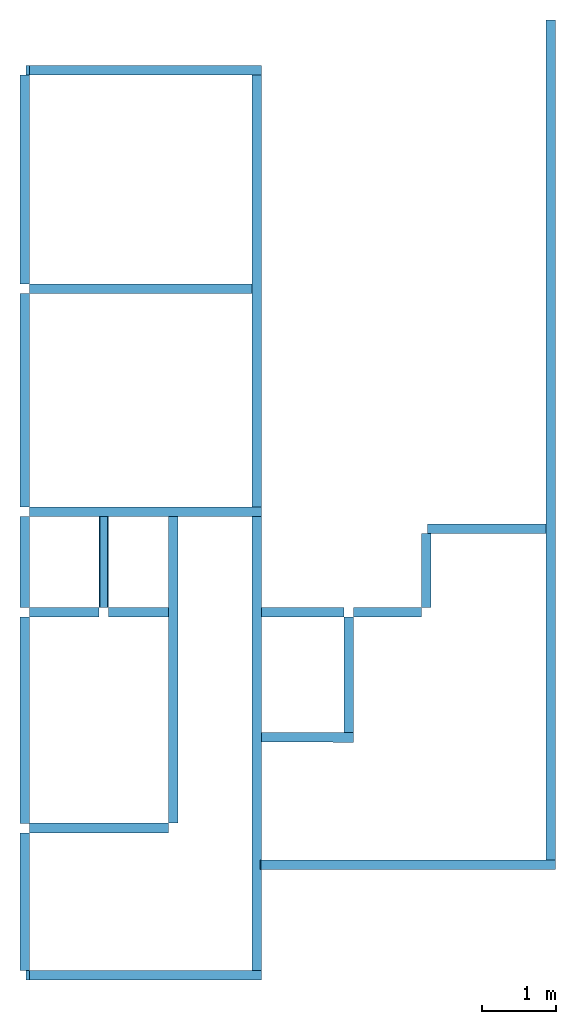
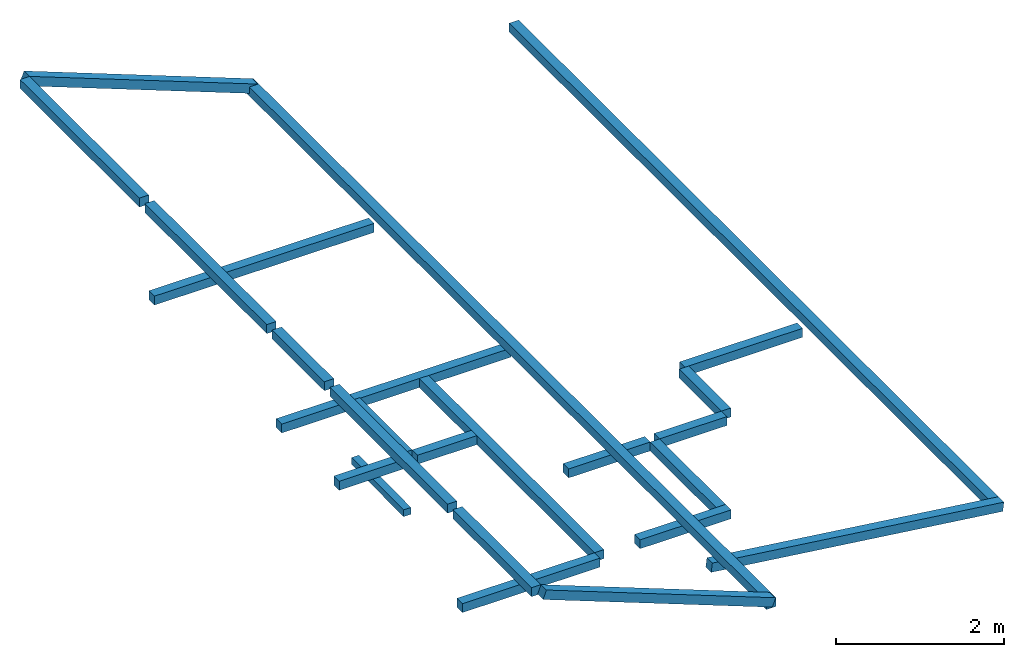
# One storey: 24 beams.
"""IFC4 building model written with IfcOpenShell, lengths in millimetres."""

import ifcopenshell
import ifcopenshell.guid

model = None  # the IFC model being written
_history = None  # IfcOwnerHistory: only IFC2X3 demands one
_inside = {}  # id of a spatial element -> (the spatial element, [elements in it])
_under = {}  # id of a project, library or spatial element -> (it, [spatial elements below it])
_declared = {}  # id of a project -> (the project, [libraries it declares])
_typed = {}  # id of a type object -> (the type object, [elements of that type])
_made_of = {}  # id of a material, layer set ... -> (it, [elements and type objects made of it])


def new_model(schema):
    """Start an empty IFC model of exactly this schema.

    Asked for "IFC4X3", IfcOpenShell would pick the latest addendum, in which some entities
    have other attributes; the version numbers below select the first issue.
    IFC2X3 requires an IfcOwnerHistory on every rooted entity: one is made here for all.
    """
    global model, _history
    if schema == "IFC4X3":
        model = ifcopenshell.file(schema_version=(4, 3, 0, 0))
    else:
        model = ifcopenshell.file(schema=schema)
    _inside.clear()
    _under.clear()
    _declared.clear()
    _typed.clear()
    _made_of.clear()
    _history = None
    if model.schema == "IFC2X3":
        org = make("IfcOrganization", Name="unknown")
        user = make(
            "IfcPersonAndOrganization",
            ThePerson=make("IfcPerson", FamilyName="unknown"),
            TheOrganization=org,
        )
        app = make(
            "IfcApplication",
            ApplicationDeveloper=org,
            Version="unknown",
            ApplicationFullName="unknown",
            ApplicationIdentifier="unknown",
        )
        _history = make(
            "IfcOwnerHistory",
            OwningUser=user,
            OwningApplication=app,
            ChangeAction="ADDED",
            CreationDate=0,
        )
    return model


def make(cls, **values):
    """One entity of the class cls with the attributes given. An attribute that is None is left unset."""
    return model.create_entity(
        cls, **{name: value for name, value in values.items() if value is not None}
    )


def entity(cls, *values):
    """Any entity or typed value of the class cls, its attributes in the order of the schema. None: left unset."""
    e = model.create_entity(cls)
    for i, value in enumerate(values):
        if value is not None:
            e[i] = value
    return e


def rooted(cls, **values):
    """An entity with a GlobalId (a new one), such as an element, a storey or a relation."""
    return make(cls, GlobalId=ifcopenshell.guid.new(), OwnerHistory=_history, **values)


def si_unit(unit_type, name, prefix=None):
    """IfcSIUnit, for example si_unit("LENGTHUNIT", "METRE", prefix="MILLI")."""
    return make("IfcSIUnit", UnitType=unit_type, Prefix=prefix, Name=name)


def converted_unit(unit_type, name, factor, base, dimensions=None, offset=None):
    """IfcConversionBasedUnit, such as the inch: factor (a typed value) times the base unit."""
    return make(
        "IfcConversionBasedUnit"
        if offset is None
        else "IfcConversionBasedUnitWithOffset",
        ConversionOffset=offset,
        Dimensions=None
        if dimensions is None
        else entity("IfcDimensionalExponents", *dimensions),
        UnitType=unit_type,
        Name=name,
        ConversionFactor=make(
            "IfcMeasureWithUnit", ValueComponent=factor, UnitComponent=base
        ),
    )


def assignment(units):
    """IfcUnitAssignment: the units of a project."""
    return None if units is None else make("IfcUnitAssignment", Units=units)


def point(xyz):
    """IfcCartesianPoint."""
    return None if xyz is None else make("IfcCartesianPoint", Coordinates=xyz)


def direction(xyz):
    """IfcDirection."""
    return None if xyz is None else make("IfcDirection", DirectionRatios=xyz)


def frame(location, z_axis=None, x_axis=None):
    """IfcAxis2Placement3D, a coordinate frame: its origin and axes. An axis left out is left unset."""
    return make(
        "IfcAxis2Placement3D",
        Location=point(location),
        Axis=direction(z_axis),
        RefDirection=direction(x_axis),
    )


def frame_2d(location, x_axis=None):
    """IfcAxis2Placement2D, a coordinate frame in the plane: its origin and x axis."""
    return make(
        "IfcAxis2Placement2D", Location=point(location), RefDirection=direction(x_axis)
    )


def origin_with_axes():
    """The frame at (0, 0, 0) with the z axis (0, 0, 1) and the x axis (1, 0, 0) written out."""
    return frame((0.0, 0.0, 0.0), z_axis=(0.0, 0.0, 1.0), x_axis=(1.0, 0.0, 0.0))


def origin_2d_with_axis():
    """The frame at (0, 0) in the plane with the x axis (1, 0) written out."""
    return frame_2d((0.0, 0.0), x_axis=(1.0, 0.0))


def place(relative_to, where):
    """IfcLocalPlacement: puts the frame where relative to a parent placement (None: the world)."""
    return make(
        "IfcLocalPlacement", PlacementRelTo=relative_to, RelativePlacement=where
    )


def context(
    kind, dimensions, precision=None, world=None, true_north=None, identifier=None
):
    """IfcGeometricRepresentationContext, for example the 3D "Model" context."""
    return make(
        "IfcGeometricRepresentationContext",
        ContextIdentifier=identifier,
        ContextType=kind,
        CoordinateSpaceDimension=dimensions,
        Precision=precision,
        WorldCoordinateSystem=world,
        TrueNorth=true_north,
    )


def subcontext(parent, identifier, kind, view, scale=None):
    """IfcGeometricRepresentationSubContext, for example "Body" below "Model"."""
    return make(
        "IfcGeometricRepresentationSubContext",
        ContextIdentifier=identifier,
        ContextType=kind,
        ParentContext=parent,
        TargetScale=scale,
        TargetView=view,
    )


def project(units=None, contexts=None):
    """IfcProject with its units and contexts."""
    return rooted(
        "IfcProject",
        Name="project",
        RepresentationContexts=contexts,
        UnitsInContext=assignment(units),
    )


def spatial(cls, under=None, at=None, **own):
    """A site, building, storey or space (cls), placed at a placement, below another one or the project."""
    s = rooted(cls, ObjectPlacement=at, **own)
    if under is not None:
        _under.setdefault(under.id(), (under, []))[1].append(s)
    return s


def profile(cls, at=None, kind="AREA", **sizes):
    """A parametric profile (cls). Its sizes go by their IFC names, for example OverallWidth=200.0."""
    return make(cls, ProfileType=kind, Position=at, **sizes)


def rectangle(**sizes):
    """IfcRectangleProfileDef."""
    return profile("IfcRectangleProfileDef", **sizes)


def extrude(swept, where, along, depth):
    """IfcExtrudedAreaSolid: the profile swept, set in the frame where, extruded along a direction by depth."""
    return make(
        "IfcExtrudedAreaSolid",
        SweptArea=swept,
        Position=where,
        ExtrudedDirection=direction(along),
        Depth=depth,
    )


def shape(context_of_items, identifier, shape_type, items):
    """IfcShapeRepresentation: the items that make up one representation, for example the "Body"."""
    return make(
        "IfcShapeRepresentation",
        ContextOfItems=context_of_items,
        RepresentationIdentifier=identifier,
        RepresentationType=shape_type,
        Items=items,
    )


def material(Name=None, Category=None):
    """IfcMaterial."""
    return make("IfcMaterial", Name=Name, Category=Category)


def material_profile(
    of_material, cross_section, Name=None, Category=None, Priority=None
):
    """IfcMaterialProfile: a cross section and its material."""
    return make(
        "IfcMaterialProfile",
        Name=Name,
        Material=of_material,
        Profile=cross_section,
        Priority=Priority,
        Category=Category,
    )


def profile_set(profiles, Name=None, composite=None):
    """IfcMaterialProfileSet."""
    return make(
        "IfcMaterialProfileSet",
        Name=Name,
        MaterialProfiles=profiles,
        CompositeProfile=composite,
    )


def profile_usage(for_profile_set, cardinal=None, extent=None):
    """IfcMaterialProfileSetUsage: how a profile set lies along its element."""
    return make(
        "IfcMaterialProfileSetUsage",
        ForProfileSet=for_profile_set,
        CardinalPoint=cardinal,
        ReferenceExtent=extent,
    )


def made_of(thing, what):
    """Note that an element or type object is made of a material, layer set ...; save() writes the relation."""
    if what is not None:
        _made_of.setdefault(what.id(), (what, []))[1].append(thing)
    return thing


def type_object(cls, material=None, **own):
    """A type object (cls), such as IfcWallType, which elements share."""
    return made_of(rooted(cls, **own), material)


def element(
    cls,
    number,
    at=None,
    inside=None,
    cuts=None,
    type_object=None,
    material=None,
    context=None,
    identifier="Body",
    shape_type=None,
    held_by="IfcProductDefinitionShape",
    body=None,
    shapes=None,
    **own,
):
    """One element of the class cls, such as IfcWall. Its Tag is "e" and its number.

    at: its placement. inside: the storey or other place that contains it. cuts: it is an
    opening in that element (IfcRelVoidsElement). A single representation is given by context,
    identifier, shape_type and body (its items); several are given by shapes. held_by: the class
    of the entity that holds the representations. save() writes the other relations.
    """
    e = rooted(cls, Tag="e%d" % number, ObjectPlacement=at, **own)
    if body is not None:
        shapes = [shape(context, identifier, shape_type, body)]
    if shapes is not None:
        e.Representation = make(held_by, Representations=shapes)
    if inside is not None:
        _inside.setdefault(inside.id(), (inside, []))[1].append(e)
    if cuts is not None:
        rooted(
            "IfcRelVoidsElement", RelatingBuildingElement=cuts, RelatedOpeningElement=e
        )
    if type_object is not None:
        _typed.setdefault(type_object.id(), (type_object, []))[1].append(e)
    return made_of(e, material)


def aggregate(whole, parts):
    """IfcRelAggregates: a whole, such as a stair, and the parts it consists of."""
    return rooted("IfcRelAggregates", RelatingObject=whole, RelatedObjects=parts)


def save(model, path):
    """Write the relations noted so far, then the file.

    IfcRelAggregates (storeys below a building ...), IfcRelContainedInSpatialStructure (elements
    in a storey), IfcRelDefinesByType, IfcRelAssociatesMaterial and IfcRelDeclares: one each for
    every whole, place, type object, material and project.
    """
    for whole, parts in _under.values():
        aggregate(whole, parts)
    for where, things in _inside.values():
        rooted(
            "IfcRelContainedInSpatialStructure",
            RelatedElements=things,
            RelatingStructure=where,
        )
    for kind, things in _typed.values():
        rooted("IfcRelDefinesByType", RelatedObjects=things, RelatingType=kind)
    for what, things in _made_of.values():
        rooted("IfcRelAssociatesMaterial", RelatedObjects=things, RelatingMaterial=what)
    for by, libraries in _declared.values():
        rooted("IfcRelDeclares", RelatingContext=by, RelatedDefinitions=libraries)
    model.write(path)


model = new_model("IFC4")

# Units and contexts
model_context = context("Model", 3, precision=1e-05, world=origin_with_axes())
plan_context = context("Plan", 2, precision=1e-05, world=origin_2d_with_axis())
body_context = subcontext(model_context, "Body", "Model", "MODEL_VIEW")
ifc_project = project(units=[si_unit("VOLUMEUNIT", "CUBIC_METRE"), si_unit("LENGTHUNIT", "METRE", prefix="MILLI"), si_unit("AREAUNIT", "SQUARE_METRE"), converted_unit("PLANEANGLEUNIT", "degree", entity("IfcReal", 0.0174532925199433), si_unit("PLANEANGLEUNIT", "RADIAN"), dimensions=[0, 0, 0, 0, 0, 0, 0])], contexts=[model_context, plan_context])

# Site, building, storey
site_placement = place(None, origin_with_axes())
site = spatial("IfcSite", under=ifc_project, at=site_placement)
building_placement = place(site_placement, origin_with_axes())
building = spatial("IfcBuilding", under=site, at=building_placement, Name="2")
storey_placement = place(building_placement, frame((0.0, 0.0, 3934.99994277954), z_axis=(0.0, 0.0, 1.0), x_axis=(1.0, 0.0, 0.0)))
storey = spatial("IfcBuildingStorey", under=building, at=storey_placement, Name="Ring")

# Beams
ifc_material = material(Name="Concrete")
ifc_material_profile_1 = material_profile(ifc_material, rectangle(XDim=130.000015258789, YDim=130.000015258789))
ifc_profile_set_1 = profile_set([ifc_material_profile_1])
ifc_profile_usage_1 = profile_usage(ifc_profile_set_1, cardinal=9)
beam_type_1 = type_object("IfcBeamType", Name="Ring", PredefinedType="BEAM", material=ifc_profile_set_1)
beam_1_placement = place(storey_placement, frame((-3934.99755859375, 4934.99994277954, 199.950218200684), z_axis=(-4.03067573621125e-15, 0.999999999999997, -7.54979012640431e-08), x_axis=(-0.999999999999989, 7.36919002924412e-15, 1.50995802528085e-07)))
element("IfcBeam", 1, at=beam_1_placement, inside=storey, type_object=beam_type_1, material=ifc_profile_usage_1, Name="Beam", context=body_context, shape_type="SweptSolid", body=[
    extrude(rectangle(XDim=130.000015258789, YDim=130.000015258789), frame((65.0000076293945, -65.0000076293945, 0.0), z_axis=(0.0, 0.0, 1.0), x_axis=(1.0, 0.0, 0.0)), (0.0, 0.0, 1.0), 12430.002377572),
])
ifc_profile_usage_2 = profile_usage(ifc_profile_set_1, cardinal=9)
beam_2_placement = place(storey_placement, frame((-7085.02197265625, 6935.00280380249, 0.000238418579101562), z_axis=(0.999999999999798, -5.52335061361681e-07, 3.13916482260166e-07), x_axis=(5.52335061361707e-07, 0.999999999999846, -5.96046128009545e-08)))
element("IfcBeam", 2, at=beam_2_placement, inside=storey, type_object=beam_type_1, material=ifc_profile_usage_2, Name="Beam", context=body_context, shape_type="SweptSolid", body=[
    extrude(rectangle(XDim=130.000015258789, YDim=130.000015258789), frame((65.0000076293945, -65.0000076293945, 0.0), z_axis=(0.0, 0.0, 1.0), x_axis=(1.0, 0.0, 0.0)), (0.0, 0.0, 1.0), 1890.02609224865),
])
ifc_profile_usage_3 = profile_usage(ifc_profile_set_1, cardinal=9)
beam_3_placement = place(storey_placement, frame((-5064.99576568604, 7065.00244140625, 0.000238418579989741), z_axis=(1.50995802528084e-07, 0.999999999999986, 7.54979012640422e-08), x_axis=(-0.999999999999988, 1.50995802528085e-07, -4.01030035845901e-08)))
element("IfcBeam", 3, at=beam_3_placement, inside=storey, type_object=beam_type_1, material=ifc_profile_usage_3, Name="Beam", context=body_context, shape_type="SweptSolid", body=[
    extrude(rectangle(XDim=130.000015258789, YDim=130.000015258789), frame((65.0000076293945, -65.0000076293945, 0.0), z_axis=(0.0, 0.0, 1.0), x_axis=(1.0, 0.0, 0.0)), (0.0, 0.0, 1.0), 4169.98293829708),
])
ifc_profile_usage_4 = profile_usage(ifc_profile_set_1, cardinal=9)
beam_4_placement = place(storey_placement, frame((-7085.00051498413, 9865.00072479248, -0.0019073486328125), z_axis=(0.999998011391369, 0.00199429442783198, 1.74442793780482e-06), x_axis=(-0.001994294427835, 0.999998011392883, -1.21110905686626e-07)))
element("IfcBeam", 4, at=beam_4_placement, inside=storey, type_object=beam_type_1, material=ifc_profile_usage_4, Name="Beam", context=body_context, shape_type="SweptSolid", body=[
    extrude(rectangle(XDim=130.000015258789, YDim=130.000015258789), frame((65.0000076293945, -65.0000076293945, 0.0), z_axis=(0.0, 0.0, 1.0), x_axis=(1.0, 0.0, 0.0)), (0.0, 0.0, 1.0), 945.627196066295),
])
ifc_profile_usage_5 = profile_usage(ifc_profile_set_1, cardinal=9)
beam_5_placement = place(storey_placement, frame((-7084.99765396118, 11235.0053787231, -0.000238418579101562), z_axis=(0.999999999999962, -1.94707169498535e-07, 1.9470718370939e-07), x_axis=(1.94707183709392e-07, 0.999999999999974, -1.19209289550778e-07)))
element("IfcBeam", 5, at=beam_5_placement, inside=storey, type_object=beam_type_1, material=ifc_profile_usage_5, Name="Beam", context=body_context, shape_type="SweptSolid", body=[
    extrude(rectangle(XDim=130.000015258789, YDim=130.000015258789), frame((65.0000076293945, -65.0000076293945, 0.0), z_axis=(0.0, 0.0, 1.0), x_axis=(1.0, 0.0, 0.0)), (0.0, 0.0, 1.0), 3149.93909141169),
])
ifc_profile_usage_6 = profile_usage(ifc_profile_set_1, cardinal=7)
beam_6_placement = place(storey_placement, frame((64.98683989048, 6434.99946594238, -724.989175796508), z_axis=(-0.99178547127658, 5.15766489691871e-07, 0.127912387845845), x_axis=(-5.2054855359522e-07, -0.999999999999865, -3.95589516699548e-09)))
element("IfcBeam", 6, at=beam_6_placement, inside=storey, type_object=beam_type_1, material=ifc_profile_usage_6, Name="Beam", context=body_context, shape_type="SweptSolid", body=[
    extrude(rectangle(XDim=130.000015258789, YDim=130.000015258789), frame((-65.0000076293945, -65.0000076293945, 0.0), z_axis=(0.0, 0.0, 1.0), x_axis=(1.0, 0.0, 0.0)), (0.0, 0.0, 1.0), 4038.60293933846),
])
ifc_profile_usage_7 = profile_usage(ifc_profile_set_1, cardinal=9)
beam_7_placement = place(storey_placement, frame((65.0004297494888, 6564.99910354614, -724.988937377929), z_axis=(1.5099578831723e-07, 0.999999999999986, 7.54979012640422e-08), x_axis=(-0.999999999999986, 1.50995802528084e-07, -7.52823794414315e-08)))
element("IfcBeam", 7, at=beam_7_placement, inside=storey, type_object=beam_type_1, material=ifc_profile_usage_7, Name="Beam", context=body_context, shape_type="SweptSolid", body=[
    extrude(rectangle(XDim=130.000015258789, YDim=130.000015258789), frame((65.0000076293945, -65.0000076293945, 0.0), z_axis=(0.0, 0.0, 1.0), x_axis=(1.0, 0.0, 0.0)), (0.0, 0.0, 1.0), 11414.9815413285),
])
ifc_profile_usage_8 = profile_usage(ifc_profile_set_1, cardinal=9)
beam_8_placement = place(storey_placement, frame((-7085.00051498413, 5065.00053405762, 1411.20910644531), z_axis=(-8.74227765734753e-08, 0.999999999999993, 7.54979012640428e-08), x_axis=(-0.999999999999992, -8.74227765734752e-08, 8.74227836789026e-08)))
element("IfcBeam", 8, at=beam_8_placement, inside=storey, type_object=beam_type_1, material=ifc_profile_usage_8, Name="Beam", context=body_context, shape_type="SweptSolid", body=[
    extrude(rectangle(XDim=130.000015258789, YDim=130.000015258789), frame((65.0000076293945, -65.0000076293945, 0.0), z_axis=(0.0, 0.0, 1.0), x_axis=(1.0, 0.0, 0.0)), (0.0, 0.0, 1.0), 1869.99989433084),
])
ifc_profile_usage_9 = profile_usage(ifc_profile_set_1, cardinal=9)
beam_9_placement = place(storey_placement, frame((-7085.00051498413, 7065.00053405762, 1411.20910644531), z_axis=(-8.74227765734753e-08, 0.999999999999993, 7.54979012640428e-08), x_axis=(-0.999999999999992, -8.74227765734752e-08, 8.74227836789026e-08)))
element("IfcBeam", 9, at=beam_9_placement, inside=storey, type_object=beam_type_1, material=ifc_profile_usage_9, Name="Beam", context=body_context, shape_type="SweptSolid", body=[
    extrude(rectangle(XDim=130.000015258789, YDim=130.000015258789), frame((65.0000076293945, -65.0000076293945, 0.0), z_axis=(0.0, 0.0, 1.0), x_axis=(1.0, 0.0, 0.0)), (0.0, 0.0, 1.0), 2800.00019754686),
])
ifc_profile_usage_10 = profile_usage(ifc_profile_set_1, cardinal=9)
beam_10_placement = place(storey_placement, frame((-7085.00051498413, 9994.99988555908, 1411.20910644531), z_axis=(2.29676311391207e-06, 0.99999999999736, 7.5497901263844e-08), x_axis=(-0.999999999997363, 2.29676311391207e-06, 1.05014219542177e-08)))
element("IfcBeam", 10, at=beam_10_placement, inside=storey, type_object=beam_type_1, material=ifc_profile_usage_10, Name="Beam", context=body_context, shape_type="SweptSolid", body=[
    extrude(rectangle(XDim=130.000015258789, YDim=130.000015258789), frame((65.0000076293945, -65.0000076293945, 0.0), z_axis=(0.0, 0.0, 1.0), x_axis=(1.0, 0.0, 0.0)), (0.0, 0.0, 1.0), 1240.00645743834),
])
ifc_profile_usage_11 = profile_usage(ifc_profile_set_1, cardinal=9)
beam_11_placement = place(storey_placement, frame((-7084.99765396118, 11365.0054931641, 1411.20910644531), z_axis=(-8.74227765734753e-08, 0.999999999999993, 7.54979012640428e-08), x_axis=(-0.999999999999992, -8.74227765734752e-08, 8.74227836789026e-08)))
element("IfcBeam", 11, at=beam_11_placement, inside=storey, type_object=beam_type_1, material=ifc_profile_usage_11, Name="Beam", context=body_context, shape_type="SweptSolid", body=[
    extrude(rectangle(XDim=130.000015258789, YDim=130.000015258789), frame((65.0000076293945, -65.0000076293945, 0.0), z_axis=(0.0, 0.0, 1.0), x_axis=(1.0, 0.0, 0.0)), (0.0, 0.0, 1.0), 2899.99964483855),
])
ifc_profile_usage_12 = profile_usage(ifc_profile_set_1, cardinal=9)
beam_12_placement = place(storey_placement, frame((-7084.99765396118, 14395.0042724609, 1411.20910644531), z_axis=(1.1046701047228e-06, 0.999999999999387, 7.5497901263997e-08), x_axis=(-0.999999999999385, 1.1046701047228e-06, -9.7267758292159e-08)))
element("IfcBeam", 12, at=beam_12_placement, inside=storey, type_object=beam_type_1, material=ifc_profile_usage_12, Name="Beam", context=body_context, shape_type="SweptSolid", body=[
    extrude(rectangle(XDim=130.000015258789, YDim=130.000015258789), frame((65.0000076293945, -65.0000076293945, 0.0), z_axis=(0.0, 0.0, 1.0), x_axis=(1.0, 0.0, 0.0)), (0.0, 0.0, 1.0), 2840.00006957989),
])
ifc_profile_usage_13 = profile_usage(ifc_profile_set_1, cardinal=9)
beam_13_placement = place(storey_placement, frame((-3934.99779701233, 8168.05553436279, -923.757076263427), z_axis=(0.999997016382449, -0.00244279065273753, -1.62920684391408e-07), x_axis=(0.00244279065273755, 0.999997016382455, -1.19209189671237e-07)))
element("IfcBeam", 13, at=beam_13_placement, inside=storey, type_object=beam_type_1, material=ifc_profile_usage_13, Name="Beam", context=body_context, shape_type="SweptSolid", body=[
    extrude(rectangle(XDim=130.000015258789, YDim=130.000015258789), frame((65.0000076293945, -65.0000076293945, 0.0), z_axis=(0.0, 0.0, 1.0), x_axis=(1.0, 0.0, 0.0)), (0.0, 0.0, 1.0), 1250.00635253662),
])
ifc_profile_usage_14 = profile_usage(ifc_profile_set_1, cardinal=9)
beam_14_placement = place(storey_placement, frame((-2684.67783927917, 8295.00198364258, -923.757314682006), z_axis=(-0.000201853104480108, 0.999999979627643, 1.94707179742753e-07), x_axis=(-0.999999979627661, -0.000201853104480112, 3.23957281062557e-08)))
element("IfcBeam", 14, at=beam_14_placement, inside=storey, type_object=beam_type_1, material=ifc_profile_usage_14, Name="Beam", context=body_context, shape_type="SweptSolid", body=[
    extrude(rectangle(XDim=130.000015258789, YDim=130.000015258789), frame((65.0000076293945, -65.0000076293945, 0.0), z_axis=(0.0, 0.0, 1.0), x_axis=(1.0, 0.0, 0.0)), (0.0, 0.0, 1.0), 1569.99874651799),
])
ifc_profile_usage_15 = profile_usage(ifc_profile_set_1, cardinal=9)
beam_15_placement = place(storey_placement, frame((-3934.99755859375, 9864.99977111816, -923.757076263427), z_axis=(0.999999999730812, -2.32020993218e-05, 1.94707183656984e-07), x_axis=(2.32020993218004e-05, 0.999999999730831, -2.98012920927069e-08)))
element("IfcBeam", 15, at=beam_15_placement, inside=storey, type_object=beam_type_1, material=ifc_profile_usage_15, Name="Beam", context=body_context, shape_type="SweptSolid", body=[
    extrude(rectangle(XDim=130.000015258789, YDim=130.000015258789), frame((65.0000076293945, -65.0000076293945, 0.0), z_axis=(0.0, 0.0, 1.0), x_axis=(1.0, 0.0, 0.0)), (0.0, 0.0, 1.0), 1120.00298716591),
])
ifc_profile_usage_16 = profile_usage(ifc_profile_set_1, cardinal=9)
beam_16_placement = place(storey_placement, frame((-2684.9946975708, 9864.99977111816, -923.757076263427), z_axis=(0.999999999999376, 1.11659494450508e-06, -4.37113882867106e-08), x_axis=(-1.11659494450508e-06, 0.999999999999375, -5.96046128009303e-08)))
element("IfcBeam", 16, at=beam_16_placement, inside=storey, type_object=beam_type_1, material=ifc_profile_usage_16, Name="Beam", context=body_context, shape_type="SweptSolid", body=[
    extrude(rectangle(XDim=130.000015258789, YDim=130.000015258789), frame((65.0000076293945, -65.0000076293945, 0.0), z_axis=(0.0, 0.0, 1.0), x_axis=(1.0, 0.0, 0.0)), (0.0, 0.0, 1.0), 924.993284304677),
])
ifc_profile_usage_17 = profile_usage(ifc_profile_set_1, cardinal=9)
beam_17_placement = place(storey_placement, frame((-1630.00023365021, 9995.15438079834, -923.757076263427), z_axis=(-1.18663084781345e-07, 0.999999970816281, -0.00024159350891549), x_axis=(-0.999999999999982, -1.18626608980319e-07, 1.50995802528084e-07)))
element("IfcBeam", 17, at=beam_17_placement, inside=storey, type_object=beam_type_1, material=ifc_profile_usage_17, Name="Beam", context=body_context, shape_type="SweptSolid", body=[
    extrude(rectangle(XDim=130.000015258789, YDim=130.000015258789), frame((65.0000076293945, -65.0000076293945, 0.0), z_axis=(0.0, 0.0, 1.0), x_axis=(1.0, 0.0, 0.0)), (0.0, 0.0, 1.0), 1004.84565060589),
])
ifc_profile_usage_18 = profile_usage(ifc_profile_set_1, cardinal=9)
beam_18_placement = place(storey_placement, frame((-1680.00030517578, 11000.0, -923.999786376952), z_axis=(0.999999999999962, -1.94707164287728e-07, 1.94707178498585e-07), x_axis=(1.94707178498587e-07, 0.999999999999974, -1.19209289550778e-07)))
element("IfcBeam", 18, at=beam_18_placement, inside=storey, type_object=beam_type_1, material=ifc_profile_usage_18, Name="Beam", context=body_context, shape_type="SweptSolid", body=[
    extrude(rectangle(XDim=130.000015258789, YDim=130.000015258789), frame((65.0000076293945, -65.0000076293945, 0.0), z_axis=(0.0, 0.0, 1.0), x_axis=(1.0, 0.0, 0.0)), (0.0, 0.0, 1.0), 1614.99789258506),
])
ifc_profile_usage_19 = profile_usage(ifc_profile_set_1, cardinal=9)
beam_19_placement = place(storey_placement, frame((-4064.99576568604, 14395.0052261353, 20.0018882751474), z_axis=(-0.999999999999962, -1.94707164287728e-07, 1.94707178498585e-07), x_axis=(1.94707178498587e-07, -0.999999999999974, 1.19209289550778e-07)))
element("IfcBeam", 19, at=beam_19_placement, inside=storey, type_object=beam_type_1, material=ifc_profile_usage_19, Name="Beam", context=body_context, shape_type="SweptSolid", body=[
    extrude(rectangle(XDim=130.000015258789, YDim=130.000015258789), frame((65.0000076293945, -65.0000076293945, 0.0), z_axis=(0.0, 0.0, 1.0), x_axis=(1.0, 0.0, 0.0)), (0.0, 0.0, 1.0), 3020.02628112877),
])
ifc_profile_usage_20 = profile_usage(ifc_profile_set_1, cardinal=9)
beam_20_placement = place(storey_placement, frame((-6009.99450683594, 9867.14363098145, 0.000238418579989741), z_axis=(0.999999999979553, 1.23580465514608e-06, 6.27438128273137e-06), x_axis=(-1.23580420042311e-06, 0.999999999999235, -5.96085669707788e-08)))
element("IfcBeam", 20, at=beam_20_placement, inside=storey, type_object=beam_type_1, material=ifc_profile_usage_20, Name="Beam", context=body_context, shape_type="SweptSolid", body=[
    extrude(rectangle(XDim=130.000015258789, YDim=130.000015258789), frame((65.0000076293945, -65.0000076293945, 0.0), z_axis=(0.0, 0.0, 1.0), x_axis=(1.0, 0.0, 0.0)), (0.0, 0.0, 1.0), 814.999111518633),
])
ifc_profile_usage_21 = profile_usage(ifc_profile_set_1, cardinal=9)
beam_21_placement = place(storey_placement, frame((-7085.00051498413, 17235.0044250488, 1411.20862960816), z_axis=(0.93298975073284, 1.21613308110189e-07, -0.359902938342353), x_axis=(-1.62920684942944e-07, 0.999999999999983, -8.443947052683e-08)))
element("IfcBeam", 21, at=beam_21_placement, inside=storey, type_object=beam_type_1, material=ifc_profile_usage_21, Name="Beam", context=body_context, shape_type="SweptSolid", body=[
    extrude(rectangle(XDim=130.000015258789, YDim=130.000015258789), frame((65.0000076293945, -65.0000076293945, 0.0), z_axis=(0.0, 0.0, 1.0), x_axis=(1.0, 0.0, 0.0)), (0.0, 0.0, 1.0), 3374.85655727029),
])
ifc_profile_usage_22 = profile_usage(ifc_profile_set_1, cardinal=9)
beam_22_placement = place(storey_placement, frame((-7084.9986076355, 4935.0004196167, 1411.20958328247), z_axis=(0.93298975073284, 1.21613308110189e-07, -0.359902938342353), x_axis=(-1.62920684942944e-07, 0.999999999999983, -8.443947052683e-08)))
element("IfcBeam", 22, at=beam_22_placement, inside=storey, type_object=beam_type_1, material=ifc_profile_usage_22, Name="Beam", context=body_context, shape_type="SweptSolid", body=[
    extrude(rectangle(XDim=130.000015258789, YDim=130.000015258789), frame((65.0000076293945, -65.0000076293945, 0.0), z_axis=(0.0, 0.0, 1.0), x_axis=(1.0, 0.0, 0.0)), (0.0, 0.0, 1.0), 3374.85655727029),
])
ifc_profile_usage_23 = profile_usage(ifc_profile_set_1, cardinal=9)
beam_23_placement = place(storey_placement, frame((-6009.99450683594, 9997.13802337646, 0.000238418579989741), z_axis=(8.80595136868757e-08, 0.999973279536084, 0.00731028137913035), x_axis=(-0.999999999999992, 8.74227765734752e-08, 8.74204459933019e-08)))
element("IfcBeam", 23, at=beam_23_placement, inside=storey, type_object=beam_type_1, material=ifc_profile_usage_23, Name="Beam", context=body_context, shape_type="SweptSolid", body=[
    extrude(rectangle(XDim=130.000015258789, YDim=130.000015258789), frame((65.0000076293945, -65.0000076293945, 0.0), z_axis=(0.0, 0.0, 1.0), x_axis=(1.0, 0.0, 0.0)), (0.0, 0.0, 1.0), 1237.90044178071),
])
ifc_material_profile_2 = material_profile(ifc_material, rectangle(XDim=100.0, YDim=100.0))
ifc_profile_set_2 = profile_set([ifc_material_profile_2])
ifc_profile_usage_24 = profile_usage(ifc_profile_set_2)
beam_type_2 = type_object("IfcBeamType", PredefinedType="BEAM", material=ifc_profile_set_2)
beam_24_placement = place(storey_placement, frame((-6074.9945640564, 9997.13706970215, -879.82153892517), z_axis=(8.80595136868757e-08, 0.999973279536084, 0.00731028137913035), x_axis=(-0.999999999999992, 8.74227765734752e-08, 8.74204459933019e-08)))
element("IfcBeam", 24, at=beam_24_placement, inside=storey, type_object=beam_type_2, material=ifc_profile_usage_24, Name="Beam", context=body_context, shape_type="SweptSolid", body=[
    extrude(rectangle(XDim=100.0, YDim=100.0), origin_with_axes(), (0.0, 0.0, 1.0), 1237.90044178071),
])

save(model, "model.ifc")
